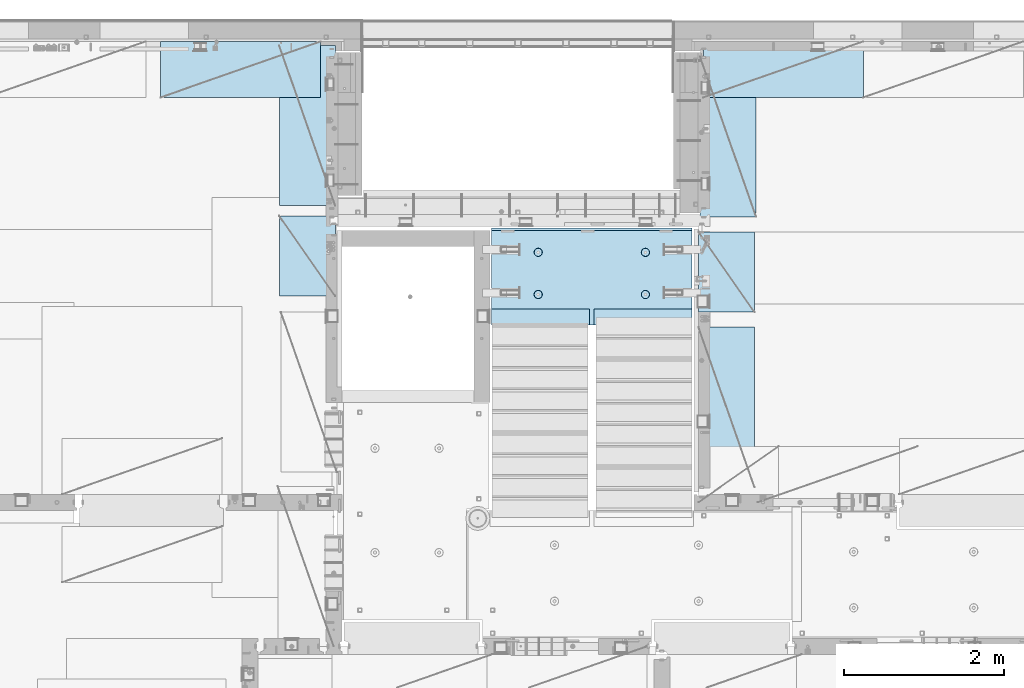
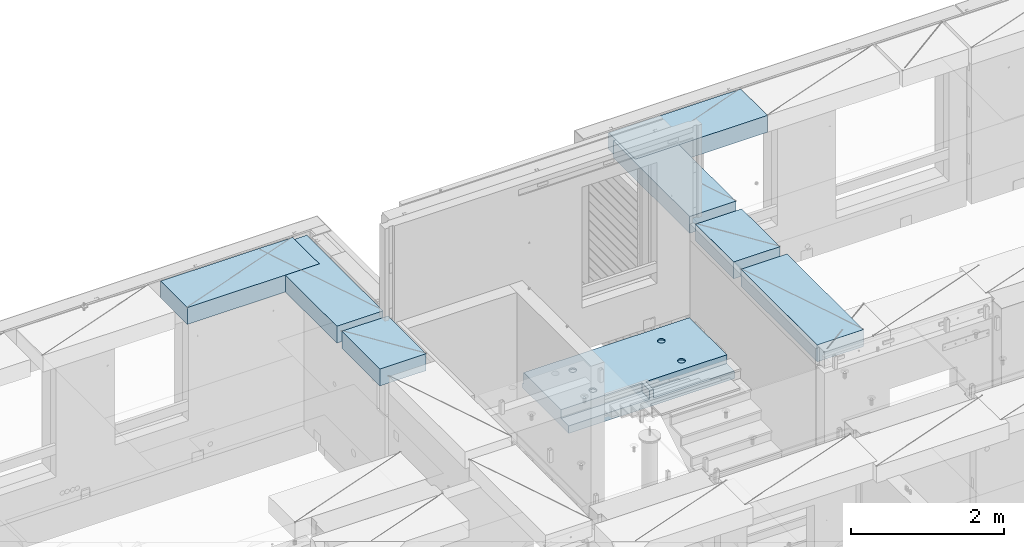
# One storey, part 209 of 350: 7 plates, 1 slab, 8 elements without a shape of their own.
"""IFC2X3 building model written with IfcOpenShell, lengths in millimetres."""

from ifc_helpers import new_model, si_unit, frame, origin_with_axes, place, context, subcontext, project, spatial, faceted_brep, material, type_object, element, aggregate, save


model = new_model("IFC2X3")

# Units and contexts
model_context = context("Model", 3, precision=1e-05, world=origin_with_axes())
body_context = subcontext(model_context, "Body", "Model", "MODEL_VIEW")
ifc_project = project(units=[si_unit("LENGTHUNIT", "METRE", prefix="MILLI"), si_unit("AREAUNIT", "SQUARE_METRE"), si_unit("VOLUMEUNIT", "CUBIC_METRE"), si_unit("MASSUNIT", "GRAM", prefix="KILO"), si_unit("TIMEUNIT", "SECOND"), si_unit("PLANEANGLEUNIT", "RADIAN"), si_unit("SOLIDANGLEUNIT", "STERADIAN"), si_unit("THERMODYNAMICTEMPERATUREUNIT", "DEGREE_CELSIUS"), si_unit("LUMINOUSINTENSITYUNIT", "LUMEN")], contexts=[model_context])

# Site, building, storey
site_placement = place(None, origin_with_axes())
site = spatial("IfcSite", under=ifc_project, at=site_placement, CompositionType="ELEMENT")
building_placement = place(site_placement, origin_with_axes())
building = spatial("IfcBuilding", under=site, at=building_placement, CompositionType="ELEMENT")
storey_placement = place(building_placement, origin_with_axes())
storey = spatial("IfcBuildingStorey", under=building, at=storey_placement, Name="2", CompositionType="ELEMENT", Elevation=0.0)

# Assembly, slab
assembly_1_placement = place(storey_placement, origin_with_axes())
assembly_1 = element("IfcElementAssembly", 1, at=assembly_1_placement, inside=storey, AssemblyPlace="NOTDEFINED", PredefinedType="REINFORCEMENT_UNIT")
ifc_material_1 = material(Name="CONCRETE/C25/30")
slab_type = type_object("IfcSlabType", PredefinedType="NOTDEFINED")
slab_placement = place(assembly_1_placement, frame((19680.000385927, 19200.0003517906, 86120.0), z_axis=(0.0, 1.0, 0.0), x_axis=(1.0, 0.0, 0.0)))
slab = element("IfcSlab", 2, at=slab_placement, type_object=slab_type, material=ifc_material_1, PredefinedType="FLOOR", context=body_context, shape_type="Brep", body=[
    faceted_brep([(1284.99890682963, -130.0, 0.0), (1284.99890682963, 10.0003972196719, 0.0), (1284.99890682963, 10.0003972196719, 200.003967285156), (1284.99890682963, -130.0, 200.003967285156), (2510.00073788432, 10.0003972196719, 200.003967285156), (2509.998046875, 10.0003972196719, 0.0), (2510.00073788432, -130.0, 200.003967285156), (2509.998046875, 60.0, 1210.00146484375), (0.0, 60.0, 1210.00146484375), (0.0, 50.0000001803419, 1180.00146538467), (2509.998046875, 50.0000001803419, 1180.00146538467), (2509.998046875, 130.0, 1210.00146484375), (0.0, 130.0, 1210.00146484375), (2509.998046875, 130.0, 0.0), (0.0, 130.0, -1.81898940354586e-12), (1225.00073788432, 10.0003972196719, 0.0), (1225.00073788432, 10.0003972196719, 200.003967285156), (-0.00109317036549328, 10.0003972196719, 200.003967285156), (0.0, 10.0003972196719, 0.0), (1225.00073788432, -130.0, 200.003967285156), (1225.00073788432, -130.0, 0.0), (0.0, -130.0, 200.003967285156), (0.0, -130.0, 1180.00146417833), (2509.998046875, -130.0, 1180.00146417833), (1940.44809334572, -110.0, 331.258272818675), (1954.3865062416, -110.0, 338.360248914683), (1965.44809334572, -110.0, 349.42183601881), (1972.55006944173, -110.0, 363.360248914683), (1974.99724362697, -110.0, 378.811098633432), (1972.55006944173, -110.0, 394.261948352181), (1965.44809334572, -110.0, 408.200361248055), (1954.3865062416, -110.0, 419.261948352181), (1940.44809334572, -110.0, 426.363924448189), (1924.99724362697, -110.0, 428.811098633432), (1909.54639390823, -110.0, 426.363924448189), (1895.60798101235, -110.0, 419.261948352181), (1884.54639390823, -110.0, 408.200361248055), (1877.44441781222, -110.0, 394.261948352181), (1874.99724362697, -110.0, 378.811098633432), (1877.44441781222, -110.0, 363.360248914683), (1884.54639390823, -110.0, 349.42183601881), (1895.60798101235, -110.0, 338.360248914683), (1909.54639390823, -110.0, 331.258272818675), (1924.99724362697, -110.0, 328.811098633432), (1974.71156152422, -130.0, 394.964259703032), (1977.2699708997, -130.0, 378.811098633432), (1967.28676833294, -130.0, 409.536236821448), (1955.72238181499, -130.0, 421.100623339393), (1941.15040469657, -130.0, 428.52541653068), (1924.99724362697, -130.0, 431.08382590616), (1908.84408255737, -130.0, 428.52541653068), (1894.27210543896, -130.0, 421.100623339393), (1882.70771892101, -130.0, 409.536236821448), (1875.28292572973, -130.0, 394.964259703032), (1872.72451635425, -130.0, 378.811098633432), (1875.28292572973, -130.0, 362.657937563832), (1882.70771892101, -130.0, 348.085960445416), (1894.27210543896, -130.0, 336.521573927472), (1908.84408255737, -130.0, 329.096780736185), (1924.99724362697, -130.0, 326.538371360704), (1941.15040469657, -130.0, 329.096780736185), (1955.72238181499, -130.0, 336.521573927472), (1967.28676833294, -130.0, 348.085960445416), (1974.71156152422, -130.0, 362.657937563832), (1940.44809334572, -110.0, 858.458272818676), (1954.3865062416, -110.0, 865.560248914684), (1965.44809334572, -110.0, 876.62183601881), (1972.55006944173, -110.0, 890.560248914684), (1974.99724362697, -110.0, 906.011098633433), (1972.55006944173, -110.0, 921.461948352182), (1965.44809334572, -110.0, 935.400361248056), (1954.3865062416, -110.0, 946.461948352182), (1940.44809334572, -110.0, 953.56392444819), (1924.99724362697, -110.0, 956.011098633433), (1909.54639390823, -110.0, 953.56392444819), (1895.60798101235, -110.0, 946.461948352182), (1884.54639390823, -110.0, 935.400361248056), (1877.44441781222, -110.0, 921.461948352182), (1874.99724362697, -110.0, 906.011098633433), (1877.44441781222, -110.0, 890.560248914684), (1884.54639390823, -110.0, 876.62183601881), (1895.60798101235, -110.0, 865.560248914684), (1909.54639390823, -110.0, 858.458272818676), (1924.99724362697, -110.0, 856.011098633433), (1974.71156152422, -130.0, 922.164259703033), (1977.2699708997, -130.0, 906.011098633433), (1967.28676833294, -130.0, 936.736236821449), (1955.72238181499, -130.0, 948.300623339394), (1941.15040469657, -130.0, 955.72541653068), (1924.99724362697, -130.0, 958.283825906161), (1908.84408255737, -130.0, 955.72541653068), (1894.27210543896, -130.0, 948.300623339394), (1882.70771892101, -130.0, 936.736236821449), (1875.28292572973, -130.0, 922.164259703033), (1872.72451635425, -130.0, 906.011098633433), (1875.28292572973, -130.0, 889.857937563833), (1882.70771892101, -130.0, 875.285960445417), (1894.27210543896, -130.0, 863.721573927472), (1908.84408255737, -130.0, 856.296780736186), (1924.99724362697, -130.0, 853.738371360705), (1941.15040469657, -130.0, 856.296780736186), (1955.72238181499, -130.0, 863.721573927472), (1967.28676833294, -130.0, 875.285960445417), (1974.71156152422, -130.0, 889.857937563833), (569.611134800252, -110.0, 426.363924448189), (555.672721904379, -110.0, 419.261948352181), (544.611134800252, -110.0, 408.200361248055), (537.509158704244, -110.0, 394.261948352181), (535.061984519001, -110.0, 378.811098633432), (537.509158704244, -110.0, 363.360248914683), (544.611134800252, -110.0, 349.42183601881), (555.672721904379, -110.0, 338.360248914683), (569.611134800252, -110.0, 331.258272818675), (585.061984519001, -110.0, 328.811098633432), (600.51283423775, -110.0, 331.258272818675), (614.451247133624, -110.0, 338.360248914683), (625.51283423775, -110.0, 349.42183601881), (632.614810333758, -110.0, 363.360248914683), (635.061984519001, -110.0, 378.811098633432), (632.614810333758, -110.0, 394.261948352181), (625.51283423775, -110.0, 408.200361248055), (614.451247133624, -110.0, 419.261948352181), (600.51283423775, -110.0, 426.363924448189), (585.061984519001, -110.0, 428.811098633432), (634.776302416249, -130.0, 394.964259703032), (637.334711791729, -130.0, 378.811098633432), (627.351509224962, -130.0, 409.536236821448), (615.787122707017, -130.0, 421.100623339393), (601.215145588601, -130.0, 428.52541653068), (585.061984519001, -130.0, 431.08382590616), (568.908823449401, -130.0, 428.52541653068), (554.336846330985, -130.0, 421.100623339393), (542.772459813041, -130.0, 409.536236821448), (535.347666621754, -130.0, 394.964259703032), (532.789257246273, -130.0, 378.811098633432), (535.347666621754, -130.0, 362.657937563832), (542.772459813041, -130.0, 348.085960445416), (554.336846330985, -130.0, 336.521573927472), (568.908823449401, -130.0, 329.096780736185), (585.061984519001, -130.0, 326.538371360704), (601.215145588601, -130.0, 329.096780736185), (615.787122707017, -130.0, 336.521573927472), (627.351509224962, -130.0, 348.085960445416), (634.776302416249, -130.0, 362.657937563832), (569.611134800252, -110.0, 953.56392444819), (555.672721904379, -110.0, 946.461948352182), (544.611134800252, -110.0, 935.400361248056), (537.509158704244, -110.0, 921.461948352182), (535.061984519001, -110.0, 906.011098633433), (537.509158704244, -110.0, 890.560248914684), (544.611134800252, -110.0, 876.62183601881), (555.672721904379, -110.0, 865.560248914684), (569.611134800252, -110.0, 858.458272818676), (585.061984519001, -110.0, 856.011098633433), (600.51283423775, -110.0, 858.458272818676), (614.451247133624, -110.0, 865.560248914684), (625.51283423775, -110.0, 876.62183601881), (632.614810333758, -110.0, 890.560248914684), (635.061984519001, -110.0, 906.011098633433), (632.614810333758, -110.0, 921.461948352182), (625.51283423775, -110.0, 935.400361248056), (614.451247133624, -110.0, 946.461948352182), (600.51283423775, -110.0, 953.56392444819), (585.061984519001, -110.0, 956.011098633433), (634.776302416249, -130.0, 922.164259703033), (637.334711791729, -130.0, 906.011098633433), (627.351509224962, -130.0, 936.736236821449), (615.787122707017, -130.0, 948.300623339394), (601.215145588601, -130.0, 955.72541653068), (585.061984519001, -130.0, 958.283825906161), (568.908823449401, -130.0, 955.72541653068), (554.336846330985, -130.0, 948.300623339394), (542.772459813041, -130.0, 936.736236821449), (535.347666621754, -130.0, 922.164259703033), (532.789257246273, -130.0, 906.011098633433), (535.347666621754, -130.0, 889.857937563833), (542.772459813041, -130.0, 875.285960445417), (554.336846330985, -130.0, 863.721573927472), (568.908823449401, -130.0, 856.296780736186), (585.061984519001, -130.0, 853.738371360705), (601.215145588601, -130.0, 856.296780736186), (615.787122707017, -130.0, 863.721573927472), (627.351509224962, -130.0, 875.285960445417), (634.776302416249, -130.0, 889.857937563833)], [[[0, 1, 2, 3]], [[4, 2, 1, 5]], [[6, 3, 2, 4]], [[7, 8, 9, 10]], [[11, 12, 8, 7]], [[11, 13, 14, 12]], [[15, 16, 17, 18]], [[19, 16, 15, 20]], [[21, 17, 16, 19]], [[22, 9, 8, 12, 14, 18, 17, 21]], [[23, 10, 9, 22]], [[5, 13, 11, 7, 10, 23, 6, 4]], [[0, 20, 15, 18, 14, 13, 5, 1]], [[24, 25, 26, 27, 28, 29, 30, 31, 32, 33, 34, 35, 36, 37, 38, 39, 40, 41, 42, 43]], [[44, 29, 28, 45]], [[46, 30, 29, 44]], [[47, 31, 30, 46]], [[48, 32, 31, 47]], [[49, 33, 32, 48]], [[50, 34, 33, 49]], [[51, 35, 34, 50]], [[52, 36, 35, 51]], [[53, 37, 36, 52]], [[54, 38, 37, 53]], [[55, 39, 38, 54]], [[56, 40, 39, 55]], [[57, 41, 40, 56]], [[58, 42, 41, 57]], [[59, 43, 42, 58]], [[60, 24, 43, 59]], [[61, 25, 24, 60]], [[62, 26, 25, 61]], [[63, 27, 26, 62]], [[45, 28, 27, 63]], [[64, 65, 66, 67, 68, 69, 70, 71, 72, 73, 74, 75, 76, 77, 78, 79, 80, 81, 82, 83]], [[84, 69, 68, 85]], [[86, 70, 69, 84]], [[87, 71, 70, 86]], [[88, 72, 71, 87]], [[89, 73, 72, 88]], [[90, 74, 73, 89]], [[91, 75, 74, 90]], [[92, 76, 75, 91]], [[93, 77, 76, 92]], [[94, 78, 77, 93]], [[95, 79, 78, 94]], [[96, 80, 79, 95]], [[97, 81, 80, 96]], [[98, 82, 81, 97]], [[99, 83, 82, 98]], [[100, 64, 83, 99]], [[101, 65, 64, 100]], [[102, 66, 65, 101]], [[103, 67, 66, 102]], [[85, 68, 67, 103]], [[104, 105, 106, 107, 108, 109, 110, 111, 112, 113, 114, 115, 116, 117, 118, 119, 120, 121, 122, 123]], [[124, 119, 118, 125]], [[126, 120, 119, 124]], [[127, 121, 120, 126]], [[128, 122, 121, 127]], [[129, 123, 122, 128]], [[130, 104, 123, 129]], [[131, 105, 104, 130]], [[132, 106, 105, 131]], [[133, 107, 106, 132]], [[134, 108, 107, 133]], [[135, 109, 108, 134]], [[136, 110, 109, 135]], [[137, 111, 110, 136]], [[138, 112, 111, 137]], [[139, 113, 112, 138]], [[140, 114, 113, 139]], [[141, 115, 114, 140]], [[142, 116, 115, 141]], [[143, 117, 116, 142]], [[125, 118, 117, 143]], [[144, 145, 146, 147, 148, 149, 150, 151, 152, 153, 154, 155, 156, 157, 158, 159, 160, 161, 162, 163]], [[164, 159, 158, 165]], [[166, 160, 159, 164]], [[167, 161, 160, 166]], [[168, 162, 161, 167]], [[169, 163, 162, 168]], [[170, 144, 163, 169]], [[171, 145, 144, 170]], [[172, 146, 145, 171]], [[173, 147, 146, 172]], [[174, 148, 147, 173]], [[175, 149, 148, 174]], [[176, 150, 149, 175]], [[177, 151, 150, 176]], [[178, 152, 151, 177]], [[179, 153, 152, 178]], [[180, 154, 153, 179]], [[181, 155, 154, 180]], [[182, 156, 155, 181]], [[183, 157, 156, 182]], [[165, 158, 157, 183]], [[23, 22, 21, 19, 20, 0, 3, 6], [182, 181, 180, 179, 178, 177, 176, 175, 174, 173, 172, 171, 170, 169, 168, 167, 166, 164, 165, 183], [142, 141, 140, 139, 138, 137, 136, 135, 134, 133, 132, 131, 130, 129, 128, 127, 126, 124, 125, 143], [102, 101, 100, 99, 98, 97, 96, 95, 94, 93, 92, 91, 90, 89, 88, 87, 86, 84, 85, 103], [62, 61, 60, 59, 58, 57, 56, 55, 54, 53, 52, 51, 50, 49, 48, 47, 46, 44, 45, 63]]]),
])
aggregate(assembly_1, [slab])

# Assembly, plate
assembly_2_placement = place(storey_placement, origin_with_axes())
assembly_2 = element("IfcElementAssembly", 3, at=assembly_2_placement, inside=storey, Name="Steel Assembly", AssemblyPlace="NOTDEFINED", PredefinedType="NOTDEFINED")
ifc_material_2 = material()
plate_type = type_object("IfcPlateType", PredefinedType="NOTDEFINED")
plate_1_placement = place(assembly_2_placement, frame((24330.0, 22740.0001220703, 87595.3), z_axis=(0.0, -1.0, 0.0), x_axis=(-1.0, 3.00000001838171e-08, 0.0)))
plate_1 = element("IfcPlate", 4, at=plate_1_placement, type_object=plate_type, material=ifc_material_2, Name="RE1", context=body_context, shape_type="Brep", body=[
    faceted_brep([(1.81898940354586e-12, -135.0, 1.81898940354586e-12), (0.0, -135.0, 699.999999999996), (0.0, 135.0, 699.999999999996), (1.81898940354586e-12, 135.0, 1.81898940354586e-12), (1999.99951171875, -135.0, 699.999999999993), (1999.99951171875, 135.0, 699.999999999993), (2000.0, -135.0, -3.63797880709171e-12), (2000.0, 135.0, -3.63797880709171e-12)], [[[0, 1, 2, 3]], [[1, 4, 5, 2]], [[4, 6, 7, 5]], [[6, 0, 3, 7]], [[5, 7, 3, 2]], [[6, 4, 1, 0]]]),
])
aggregate(assembly_2, [plate_1])

assembly_3_placement = place(storey_placement, origin_with_axes())
assembly_3 = element("IfcElementAssembly", 5, at=assembly_3_placement, inside=storey, Name="Steel Assembly", AssemblyPlace="NOTDEFINED", PredefinedType="NOTDEFINED")
plate_2_placement = place(assembly_3_placement, frame((17730.0001220703, 20690.0, 87595.3), z_axis=(-1.0, 3.00000001838171e-08, 0.0), x_axis=(0.0, 1.0, 0.0)))
plate_2 = element("IfcPlate", 6, at=plate_2_placement, type_object=plate_type, material=ifc_material_2, Name="RE1", context=body_context, shape_type="Brep", body=[
    faceted_brep([(1.81898940354586e-12, -135.0, 1.81898940354586e-12), (0.0, -135.0, 699.999999999996), (0.0, 135.0, 699.999999999996), (1.81898940354586e-12, 135.0, 1.81898940354586e-12), (1999.99951171875, -135.0, 699.999999999993), (1999.99951171875, 135.0, 699.999999999993), (2000.0, -135.0, -3.63797880709171e-12), (2000.0, 135.0, -3.63797880709171e-12)], [[[0, 1, 2, 3]], [[1, 4, 5, 2]], [[4, 6, 7, 5]], [[6, 0, 3, 7]], [[5, 7, 3, 2]], [[6, 4, 1, 0]]]),
])
aggregate(assembly_3, [plate_2])

assembly_4_placement = place(storey_placement, origin_with_axes())
assembly_4 = element("IfcElementAssembly", 7, at=assembly_4_placement, inside=storey, Name="Steel Assembly", AssemblyPlace="NOTDEFINED", PredefinedType="NOTDEFINED")
plate_3_placement = place(assembly_4_placement, frame((22269.9998779297, 19170.0, 87595.3), z_axis=(1.0, 0.0, 0.0), x_axis=(0.0, -1.0, 0.0)))
plate_3 = element("IfcPlate", 8, at=plate_3_placement, type_object=plate_type, material=ifc_material_2, Name="RE1", context=body_context, shape_type="Brep", body=[
    faceted_brep([(1.81898940354586e-12, -135.0, 1.81898940354586e-12), (0.0, -135.0, 699.999999999996), (0.0, 135.0, 699.999999999996), (1.81898940354586e-12, 135.0, 1.81898940354586e-12), (1999.99951171875, -135.0, 699.999999999993), (1999.99951171875, 135.0, 699.999999999993), (2000.0, -135.0, -3.63797880709171e-12), (2000.0, 135.0, -3.63797880709171e-12)], [[[0, 1, 2, 3]], [[1, 4, 5, 2]], [[4, 6, 7, 5]], [[6, 0, 3, 7]], [[5, 7, 3, 2]], [[6, 4, 1, 0]]]),
])
aggregate(assembly_4, [plate_3])

assembly_5_placement = place(storey_placement, origin_with_axes())
assembly_5 = element("IfcElementAssembly", 9, at=assembly_5_placement, inside=storey, Name="Steel Assembly", AssemblyPlace="NOTDEFINED", PredefinedType="NOTDEFINED")
plate_4_placement = place(assembly_5_placement, frame((22289.9998779297, 22550.0, 87595.3), z_axis=(1.0, 0.0, 0.0), x_axis=(0.0, -1.0, 0.0)))
plate_4 = element("IfcPlate", 10, at=plate_4_placement, type_object=plate_type, material=ifc_material_2, Name="RE1", context=body_context, shape_type="Brep", body=[
    faceted_brep([(1.81898940354586e-12, -135.0, 1.81898940354586e-12), (0.0, -135.0, 699.999999999996), (0.0, 135.0, 699.999999999996), (1.81898940354586e-12, 135.0, 1.81898940354586e-12), (1999.99951171875, -135.0, 699.999999999993), (1999.99951171875, 135.0, 699.999999999993), (2000.0, -135.0, -3.63797880709171e-12), (2000.0, 135.0, -3.63797880709171e-12)], [[[0, 1, 2, 3]], [[1, 4, 5, 2]], [[4, 6, 7, 5]], [[6, 0, 3, 7]], [[5, 7, 3, 2]], [[6, 4, 1, 0]]]),
])
aggregate(assembly_5, [plate_4])

assembly_6_placement = place(storey_placement, origin_with_axes())
assembly_6 = element("IfcElementAssembly", 11, at=assembly_6_placement, inside=storey, Name="Steel Assembly", AssemblyPlace="NOTDEFINED", PredefinedType="NOTDEFINED")
plate_5_placement = place(assembly_6_placement, frame((22269.9999999293, 20360.0, 87595.3), z_axis=(1.0, 0.0, 0.0), x_axis=(0.0, -1.0, 0.0)))
plate_5 = element("IfcPlate", 12, at=plate_5_placement, type_object=plate_type, material=ifc_material_2, Name="RE1_1/2", context=body_context, shape_type="Brep", body=[
    faceted_brep([(1.81898940354586e-12, -135.0, 1.81898940354586e-12), (0.0, -135.0, 699.999999999996), (0.0, 135.0, 699.999999999996), (1.81898940354586e-12, 135.0, 1.81898940354586e-12), (999.99951171875, -135.0, 700.0), (999.99951171875, 135.0, 700.0), (1000.0, -135.0, 0.0), (1000.0, 135.0, 0.0)], [[[0, 1, 2, 3]], [[1, 4, 5, 2]], [[4, 6, 7, 5]], [[6, 0, 3, 7]], [[5, 7, 3, 2]], [[6, 4, 1, 0]]]),
])
aggregate(assembly_6, [plate_5])

assembly_7_placement = place(storey_placement, origin_with_axes())
assembly_7 = element("IfcElementAssembly", 13, at=assembly_7_placement, inside=storey, Name="Steel Assembly", AssemblyPlace="NOTDEFINED", PredefinedType="NOTDEFINED")
plate_6_placement = place(assembly_7_placement, frame((17730.0000000707, 19560.0, 87595.3), z_axis=(-1.0, 3.00000001838171e-08, 0.0), x_axis=(0.0, 1.0, 0.0)))
plate_6 = element("IfcPlate", 14, at=plate_6_placement, type_object=plate_type, material=ifc_material_2, Name="RE1_1/2", context=body_context, shape_type="Brep", body=[
    faceted_brep([(1.81898940354586e-12, -135.0, 1.81898940354586e-12), (0.0, -135.0, 699.999999999996), (0.0, 135.0, 699.999999999996), (1.81898940354586e-12, 135.0, 1.81898940354586e-12), (999.99951171875, -135.0, 700.0), (999.99951171875, 135.0, 700.0), (1000.0, -135.0, 0.0), (1000.0, 135.0, 0.0)], [[[0, 1, 2, 3]], [[1, 4, 5, 2]], [[4, 6, 7, 5]], [[6, 0, 3, 7]], [[5, 7, 3, 2]], [[6, 4, 1, 0]]]),
])
aggregate(assembly_7, [plate_6])

assembly_8_placement = place(storey_placement, origin_with_axes())
assembly_8 = element("IfcElementAssembly", 15, at=assembly_8_placement, inside=storey, Name="Steel Assembly", AssemblyPlace="NOTDEFINED", PredefinedType="NOTDEFINED")
plate_7_placement = place(assembly_8_placement, frame((17545.0, 22740.0001220703, 87595.3), z_axis=(0.0, -1.0, 0.0), x_axis=(-1.0, 3.00000001838171e-08, 0.0)))
plate_7 = element("IfcPlate", 16, at=plate_7_placement, type_object=plate_type, material=ifc_material_2, Name="RE1", context=body_context, shape_type="Brep", body=[
    faceted_brep([(1.81898940354586e-12, -135.0, 1.81898940354586e-12), (0.0, -135.0, 699.999999999996), (0.0, 135.0, 699.999999999996), (1.81898940354586e-12, 135.0, 1.81898940354586e-12), (1999.99951171875, -135.0, 699.999999999993), (1999.99951171875, 135.0, 699.999999999993), (2000.0, -135.0, -3.63797880709171e-12), (2000.0, 135.0, -3.63797880709171e-12)], [[[0, 1, 2, 3]], [[1, 4, 5, 2]], [[4, 6, 7, 5]], [[6, 0, 3, 7]], [[5, 7, 3, 2]], [[6, 4, 1, 0]]]),
])
aggregate(assembly_8, [plate_7])

save(model, "model.ifc")
